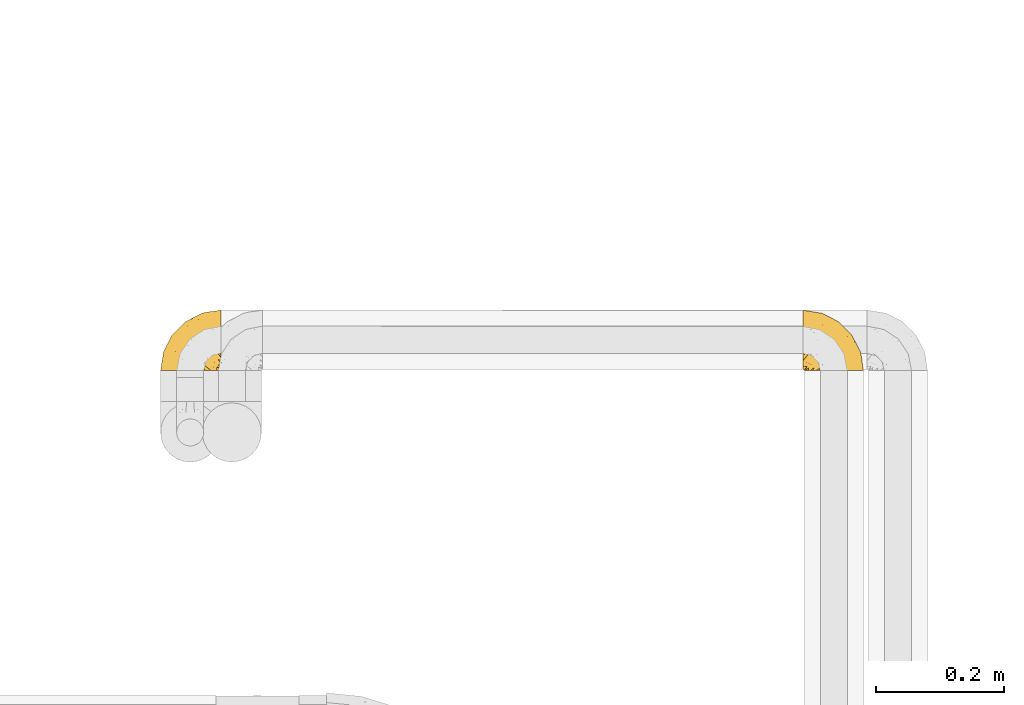
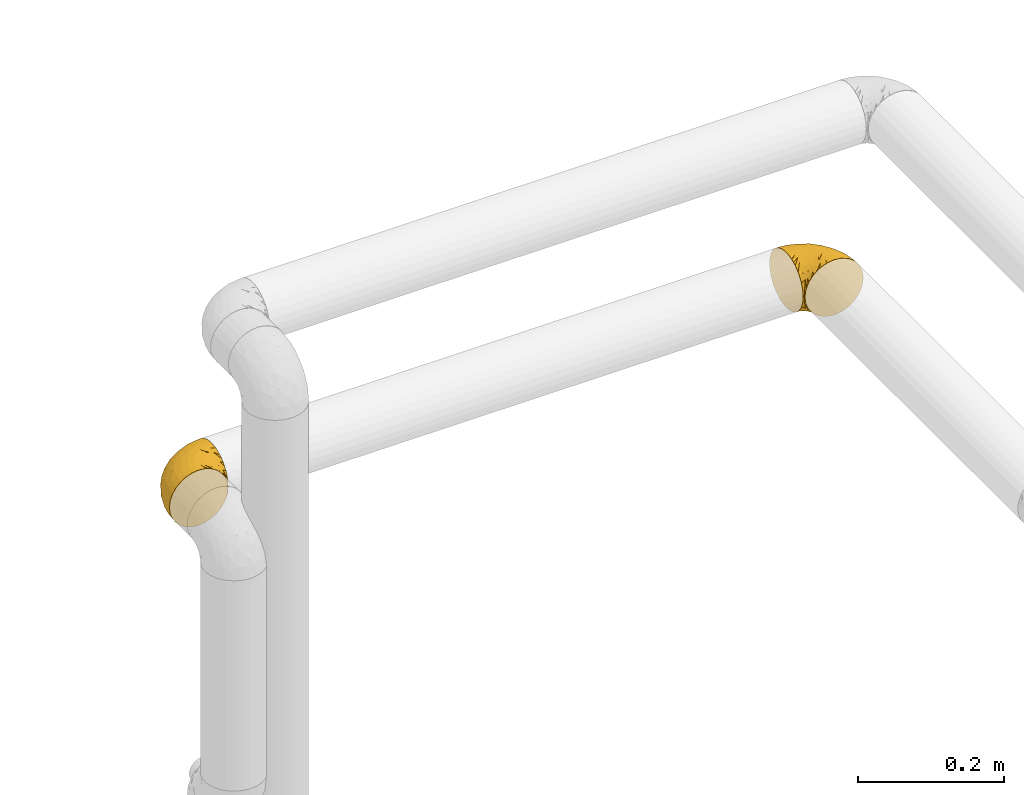
# One storey, part 513 of 827: 2 coverings.
"""IFC2X3 building model written with IfcOpenShell, lengths in millimetres."""

import ifcopenshell
import ifcopenshell.guid

model = None  # the IFC model being written
_history = None  # IfcOwnerHistory: only IFC2X3 demands one
_inside = {}  # id of a spatial element -> (the spatial element, [elements in it])
_under = {}  # id of a project, library or spatial element -> (it, [spatial elements below it])
_declared = {}  # id of a project -> (the project, [libraries it declares])
_typed = {}  # id of a type object -> (the type object, [elements of that type])
_made_of = {}  # id of a material, layer set ... -> (it, [elements and type objects made of it])


def new_model(schema):
    """Start an empty IFC model of exactly this schema.

    Asked for "IFC4X3", IfcOpenShell would pick the latest addendum, in which some entities
    have other attributes; the version numbers below select the first issue.
    IFC2X3 requires an IfcOwnerHistory on every rooted entity: one is made here for all.
    """
    global model, _history
    if schema == "IFC4X3":
        model = ifcopenshell.file(schema_version=(4, 3, 0, 0))
    else:
        model = ifcopenshell.file(schema=schema)
    _inside.clear()
    _under.clear()
    _declared.clear()
    _typed.clear()
    _made_of.clear()
    _history = None
    if model.schema == "IFC2X3":
        org = make("IfcOrganization", Name="unknown")
        user = make(
            "IfcPersonAndOrganization",
            ThePerson=make("IfcPerson", FamilyName="unknown"),
            TheOrganization=org,
        )
        app = make(
            "IfcApplication",
            ApplicationDeveloper=org,
            Version="unknown",
            ApplicationFullName="unknown",
            ApplicationIdentifier="unknown",
        )
        _history = make(
            "IfcOwnerHistory",
            OwningUser=user,
            OwningApplication=app,
            ChangeAction="ADDED",
            CreationDate=0,
        )
    return model


def make(cls, **values):
    """One entity of the class cls with the attributes given. An attribute that is None is left unset."""
    return model.create_entity(
        cls, **{name: value for name, value in values.items() if value is not None}
    )


def entity(cls, *values):
    """Any entity or typed value of the class cls, its attributes in the order of the schema. None: left unset."""
    e = model.create_entity(cls)
    for i, value in enumerate(values):
        if value is not None:
            e[i] = value
    return e


def rooted(cls, **values):
    """An entity with a GlobalId (a new one), such as an element, a storey or a relation."""
    return make(cls, GlobalId=ifcopenshell.guid.new(), OwnerHistory=_history, **values)


def si_unit(unit_type, name, prefix=None):
    """IfcSIUnit, for example si_unit("LENGTHUNIT", "METRE", prefix="MILLI")."""
    return make("IfcSIUnit", UnitType=unit_type, Prefix=prefix, Name=name)


def converted_unit(unit_type, name, factor, base, dimensions=None, offset=None):
    """IfcConversionBasedUnit, such as the inch: factor (a typed value) times the base unit."""
    return make(
        "IfcConversionBasedUnit"
        if offset is None
        else "IfcConversionBasedUnitWithOffset",
        ConversionOffset=offset,
        Dimensions=None
        if dimensions is None
        else entity("IfcDimensionalExponents", *dimensions),
        UnitType=unit_type,
        Name=name,
        ConversionFactor=make(
            "IfcMeasureWithUnit", ValueComponent=factor, UnitComponent=base
        ),
    )


def derived_unit(unit_type, elements):
    """IfcDerivedUnit: a product of units, each with its exponent."""
    return make(
        "IfcDerivedUnit",
        Elements=[
            make("IfcDerivedUnitElement", Unit=unit, Exponent=power)
            for unit, power in elements
        ],
        UnitType=unit_type,
    )


def assignment(units):
    """IfcUnitAssignment: the units of a project."""
    return None if units is None else make("IfcUnitAssignment", Units=units)


def point(xyz):
    """IfcCartesianPoint."""
    return None if xyz is None else make("IfcCartesianPoint", Coordinates=xyz)


def direction(xyz):
    """IfcDirection."""
    return None if xyz is None else make("IfcDirection", DirectionRatios=xyz)


def frame(location, z_axis=None, x_axis=None):
    """IfcAxis2Placement3D, a coordinate frame: its origin and axes. An axis left out is left unset."""
    return make(
        "IfcAxis2Placement3D",
        Location=point(location),
        Axis=direction(z_axis),
        RefDirection=direction(x_axis),
    )


def origin():
    """The frame at (0, 0, 0) with its axes left unset."""
    return frame((0.0, 0.0, 0.0))


def place(relative_to, where):
    """IfcLocalPlacement: puts the frame where relative to a parent placement (None: the world)."""
    return make(
        "IfcLocalPlacement", PlacementRelTo=relative_to, RelativePlacement=where
    )


def context(
    kind, dimensions, precision=None, world=None, true_north=None, identifier=None
):
    """IfcGeometricRepresentationContext, for example the 3D "Model" context."""
    return make(
        "IfcGeometricRepresentationContext",
        ContextIdentifier=identifier,
        ContextType=kind,
        CoordinateSpaceDimension=dimensions,
        Precision=precision,
        WorldCoordinateSystem=world,
        TrueNorth=true_north,
    )


def subcontext(parent, identifier, kind, view, scale=None):
    """IfcGeometricRepresentationSubContext, for example "Body" below "Model"."""
    return make(
        "IfcGeometricRepresentationSubContext",
        ContextIdentifier=identifier,
        ContextType=kind,
        ParentContext=parent,
        TargetScale=scale,
        TargetView=view,
    )


def project(units=None, contexts=None):
    """IfcProject with its units and contexts."""
    return rooted(
        "IfcProject",
        Name="project",
        RepresentationContexts=contexts,
        UnitsInContext=assignment(units),
    )


def spatial(cls, under=None, at=None, **own):
    """A site, building, storey or space (cls), placed at a placement, below another one or the project."""
    s = rooted(cls, ObjectPlacement=at, **own)
    if under is not None:
        _under.setdefault(under.id(), (under, []))[1].append(s)
    return s


def faces_of(points, faces, orient=None, outer=None):
    """IfcFace entities. A face is a list of loops; a loop is a list of indices into points, from 0.

    orient and outer hold one flag for each loop. By default every Orientation is true, the
    first loop of a face is its IfcFaceOuterBound and the others are IfcFaceBound.
    """
    made = []
    for i, loops in enumerate(faces):
        bounds = []
        for j, loop in enumerate(loops):
            is_outer = j == 0 if outer is None else outer[i][j]
            bounds.append(
                make(
                    "IfcFaceOuterBound" if is_outer else "IfcFaceBound",
                    Bound=make("IfcPolyLoop", Polygon=[points[k] for k in loop]),
                    Orientation=True if orient is None else orient[i][j],
                )
            )
        made.append(make("IfcFace", Bounds=bounds))
    return made


def faceted_brep(points, faces, orient=None, outer=None, voids=None):
    """IfcFacetedBrep: a solid bounded by flat faces; with voids (closed shells), ...WithVoids."""
    shared = [point(p) for p in points]
    hull = make("IfcClosedShell", CfsFaces=faces_of(shared, faces, orient, outer))
    if voids is None:
        return make("IfcFacetedBrep", Outer=hull)
    return make(
        "IfcFacetedBrepWithVoids",
        Outer=hull,
        Voids=[
            make(cls, CfsFaces=faces_of(shared, fs, o, b)) for cls, fs, o, b in voids
        ],
    )


def shape(context_of_items, identifier, shape_type, items):
    """IfcShapeRepresentation: the items that make up one representation, for example the "Body"."""
    return make(
        "IfcShapeRepresentation",
        ContextOfItems=context_of_items,
        RepresentationIdentifier=identifier,
        RepresentationType=shape_type,
        Items=items,
    )


def made_of(thing, what):
    """Note that an element or type object is made of a material, layer set ...; save() writes the relation."""
    if what is not None:
        _made_of.setdefault(what.id(), (what, []))[1].append(thing)
    return thing


def element(
    cls,
    number,
    at=None,
    inside=None,
    cuts=None,
    type_object=None,
    material=None,
    context=None,
    identifier="Body",
    shape_type=None,
    held_by="IfcProductDefinitionShape",
    body=None,
    shapes=None,
    **own,
):
    """One element of the class cls, such as IfcWall. Its Tag is "e" and its number.

    at: its placement. inside: the storey or other place that contains it. cuts: it is an
    opening in that element (IfcRelVoidsElement). A single representation is given by context,
    identifier, shape_type and body (its items); several are given by shapes. held_by: the class
    of the entity that holds the representations. save() writes the other relations.
    """
    e = rooted(cls, Tag="e%d" % number, ObjectPlacement=at, **own)
    if body is not None:
        shapes = [shape(context, identifier, shape_type, body)]
    if shapes is not None:
        e.Representation = make(held_by, Representations=shapes)
    if inside is not None:
        _inside.setdefault(inside.id(), (inside, []))[1].append(e)
    if cuts is not None:
        rooted(
            "IfcRelVoidsElement", RelatingBuildingElement=cuts, RelatedOpeningElement=e
        )
    if type_object is not None:
        _typed.setdefault(type_object.id(), (type_object, []))[1].append(e)
    return made_of(e, material)


def aggregate(whole, parts):
    """IfcRelAggregates: a whole, such as a stair, and the parts it consists of."""
    return rooted("IfcRelAggregates", RelatingObject=whole, RelatedObjects=parts)


def save(model, path):
    """Write the relations noted so far, then the file.

    IfcRelAggregates (storeys below a building ...), IfcRelContainedInSpatialStructure (elements
    in a storey), IfcRelDefinesByType, IfcRelAssociatesMaterial and IfcRelDeclares: one each for
    every whole, place, type object, material and project.
    """
    for whole, parts in _under.values():
        aggregate(whole, parts)
    for where, things in _inside.values():
        rooted(
            "IfcRelContainedInSpatialStructure",
            RelatedElements=things,
            RelatingStructure=where,
        )
    for kind, things in _typed.values():
        rooted("IfcRelDefinesByType", RelatedObjects=things, RelatingType=kind)
    for what, things in _made_of.values():
        rooted("IfcRelAssociatesMaterial", RelatedObjects=things, RelatingMaterial=what)
    for by, libraries in _declared.values():
        rooted("IfcRelDeclares", RelatingContext=by, RelatedDefinitions=libraries)
    model.write(path)


model = new_model("IFC2X3")

# Units and contexts
model_context = context("Model", 3, precision=0.01, world=origin(), true_north=direction((6.12303176911189e-17, 1.0)))
body_context = subcontext(model_context, "Body", "Model", "MODEL_VIEW")
ifc_project = project(units=[si_unit("LENGTHUNIT", "METRE", prefix="MILLI"), si_unit("AREAUNIT", "SQUARE_METRE"), si_unit("VOLUMEUNIT", "CUBIC_METRE"), converted_unit("PLANEANGLEUNIT", "DEGREE", entity("IfcRatioMeasure", 0.0174532925199433), si_unit("PLANEANGLEUNIT", "RADIAN"), dimensions=[0, 0, 0, 0, 0, 0, 0]), si_unit("MASSUNIT", "GRAM", prefix="KILO"), derived_unit("MASSDENSITYUNIT", [(si_unit("MASSUNIT", "GRAM", prefix="KILO"), 1), (si_unit("LENGTHUNIT", "METRE"), -3)]), derived_unit("MOMENTOFINERTIAUNIT", [(si_unit("LENGTHUNIT", "METRE"), 4)]), si_unit("TIMEUNIT", "SECOND"), si_unit("FREQUENCYUNIT", "HERTZ"), si_unit("THERMODYNAMICTEMPERATUREUNIT", "DEGREE_CELSIUS"), derived_unit("THERMALTRANSMITTANCEUNIT", [(si_unit("MASSUNIT", "GRAM", prefix="KILO"), 1), (si_unit("THERMODYNAMICTEMPERATUREUNIT", "KELVIN"), -1), (si_unit("TIMEUNIT", "SECOND"), -3)]), derived_unit("VOLUMETRICFLOWRATEUNIT", [(si_unit("LENGTHUNIT", "METRE"), 3), (si_unit("TIMEUNIT", "SECOND"), -1)]), derived_unit("MASSFLOWRATEUNIT", [(si_unit("MASSUNIT", "GRAM", prefix="KILO"), 1), (si_unit("TIMEUNIT", "SECOND"), -1)]), derived_unit("ROTATIONALFREQUENCYUNIT", [(si_unit("TIMEUNIT", "SECOND"), -1)]), si_unit("ELECTRICCURRENTUNIT", "AMPERE"), si_unit("ELECTRICVOLTAGEUNIT", "VOLT"), si_unit("POWERUNIT", "WATT"), si_unit("FORCEUNIT", "NEWTON", prefix="KILO"), si_unit("ILLUMINANCEUNIT", "LUX"), si_unit("LUMINOUSFLUXUNIT", "LUMEN"), si_unit("LUMINOUSINTENSITYUNIT", "CANDELA"), derived_unit("USERDEFINED", [(si_unit("MASSUNIT", "GRAM", prefix="KILO"), -1), (si_unit("LENGTHUNIT", "METRE"), -2), (si_unit("TIMEUNIT", "SECOND"), 3), (si_unit("LUMINOUSFLUXUNIT", "LUMEN"), 1)]), derived_unit("LINEARVELOCITYUNIT", [(si_unit("LENGTHUNIT", "METRE"), 1), (si_unit("TIMEUNIT", "SECOND"), -1)]), si_unit("PRESSUREUNIT", "PASCAL"), derived_unit("USERDEFINED", [(si_unit("LENGTHUNIT", "METRE"), -2), (si_unit("MASSUNIT", "GRAM", prefix="KILO"), 1), (si_unit("TIMEUNIT", "SECOND"), -2)]), derived_unit("LINEARFORCEUNIT", [(si_unit("MASSUNIT", "GRAM", prefix="KILO"), 1), (si_unit("LENGTHUNIT", "METRE"), 1), (si_unit("TIMEUNIT", "SECOND"), -2), (si_unit("LENGTHUNIT", "METRE"), -1)]), derived_unit("PLANARFORCEUNIT", [(si_unit("MASSUNIT", "GRAM", prefix="KILO"), 1), (si_unit("LENGTHUNIT", "METRE"), 1), (si_unit("TIMEUNIT", "SECOND"), -2), (si_unit("LENGTHUNIT", "METRE"), -2)])], contexts=[model_context])

# Site, building, storey
site_placement = place(None, origin())
site = spatial("IfcSite", under=ifc_project, at=site_placement, CompositionType="ELEMENT")
building_placement = place(site_placement, origin())
building = spatial("IfcBuilding", under=site, at=building_placement, CompositionType="ELEMENT")
storey_placement = place(building_placement, frame((0.0, 0.0, 28200.0)))
storey = spatial("IfcBuildingStorey", under=building, at=storey_placement, Name="08", CompositionType="ELEMENT", Elevation=28200.0)

# Coverings
covering_1_placement = place(storey_placement, frame((61003.04, 18766.35, 2041.58)))
element("IfcCovering", 1, at=covering_1_placement, inside=storey, Name=":ADSK_", ObjectType=":ADSK_", PredefinedType="INSULATION", context=body_context, shape_type="Brep", body=[
    faceted_brep([(1.6, 78.41, 83.91), (1.6, 85.72, 76.59), (1.6, 91.22, 67.83), (1.6, 94.64, 58.07), (1.6, 95.8, 47.8), (1.6, 94.64, 37.51), (1.6, 91.22, 27.74), (1.6, 85.71, 18.98), (1.6, 78.39, 11.67), (1.6, 69.63, 6.17), (1.6, 59.87, 2.75), (1.6, 49.6, 1.6), (1.6, 45.45, 2.06), (1.6, 42.38, 2.41), (1.6, 39.31, 2.75), (1.6, 34.43, 4.46), (1.6, 29.54, 6.17), (1.6, 25.16, 8.93), (1.6, 20.78, 11.68), (1.6, 17.13, 15.34), (1.6, 13.47, 19.0), (1.6, 7.97, 27.76), (1.6, 6.26, 32.64), (1.6, 4.55, 37.52), (1.6, 3.4, 47.8), (1.6, 4.55, 58.08), (1.6, 6.26, 62.96), (1.6, 7.97, 67.85), (1.6, 13.48, 76.61), (1.6, 17.14, 80.26), (1.6, 20.8, 83.92), (1.6, 25.18, 86.67), (1.6, 29.56, 89.42), (1.6, 34.44, 91.13), (1.6, 39.32, 92.84), (1.6, 42.39, 93.18), (1.6, 45.45, 93.53), (1.6, 49.6, 94.0), (1.6, 59.88, 92.84), (1.6, 69.65, 89.42), (3.4, 1.6, 47.8), (4.97, 1.6, 35.84), (9.58, 1.6, 24.7), (13.26, 1.6, 19.91), (16.93, 1.6, 15.13), (21.71, 1.6, 11.46), (26.5, 1.6, 7.78), (32.07, 1.6, 5.48), (37.64, 1.6, 3.17), (41.25, 1.6, 2.69), (43.34, 1.6, 2.42), (45.42, 1.6, 2.14), (49.6, 1.6, 1.6), (61.55, 1.6, 3.17), (72.7, 1.6, 7.78), (82.26, 1.6, 15.13), (89.61, 1.6, 24.7), (94.22, 1.6, 35.84), (95.8, 1.6, 47.8), (94.22, 1.6, 59.75), (89.61, 1.6, 70.9), (82.26, 1.6, 80.46), (72.7, 1.6, 87.81), (61.55, 1.6, 92.42), (49.6, 1.6, 94.0), (45.42, 1.6, 93.45), (41.25, 1.6, 92.9), (37.64, 1.6, 92.42), (32.07, 1.6, 90.11), (26.5, 1.6, 87.81), (21.71, 1.6, 84.13), (16.93, 1.6, 80.46), (13.26, 1.6, 75.68), (9.58, 1.6, 70.9), (4.97, 1.6, 59.75), (81.55, 36.81, 71.98), (90.4, 23.28, 63.6), (83.0, 45.8, 59.72), (91.18, 30.7, 47.8), (93.13, 21.2, 55.16), (94.0, 12.96, 47.8), (66.19, 66.19, 63.76), (70.92, 54.51, 72.22), (85.95, 17.98, 74.18), (49.74, 36.69, 92.52), (35.54, 35.54, 94.0), (38.14, 31.64, 94.0), (40.74, 27.75, 94.0), (43.34, 23.86, 94.0), (45.94, 19.96, 94.0), (77.59, 22.8, 82.14), (71.17, 42.67, 80.34), (65.81, 33.21, 87.52), (59.03, 59.45, 79.59), (45.85, 71.5, 78.25), (45.79, 62.66, 85.01), (41.42, 54.5, 90.25), (34.51, 47.57, 93.2), (56.04, 48.81, 87.23), (15.15, 74.98, 85.55), (56.51, 18.7, 93.0), (68.39, 15.75, 89.31), (23.33, 91.17, 61.31), (42.86, 85.28, 56.86), (39.42, 82.58, 68.34), (53.58, 75.78, 65.71), (59.17, 74.98, 56.99), (59.06, 67.27, 72.15), (22.63, 87.38, 70.34), (20.55, 82.04, 78.36), (12.96, 94.0, 47.8), (56.96, 77.8, 47.8), (67.38, 67.38, 47.8), (18.72, 56.2, 93.06), (5.33, 48.85, 94.0), (9.07, 48.11, 94.0), (11.79, 47.57, 94.0), (14.51, 47.03, 94.0), (17.24, 46.48, 94.0), (19.96, 45.94, 94.0), (21.03, 65.78, 89.88), (46.48, 17.24, 94.0), (47.03, 14.51, 94.0), (47.57, 11.79, 94.0), (48.11, 9.07, 94.0), (48.48, 7.2, 94.0), (48.85, 5.33, 94.0), (30.7, 91.18, 47.8), (23.86, 43.34, 94.0), (27.75, 40.74, 94.0), (31.64, 38.14, 94.0), (31.26, 72.73, 83.7), (77.8, 56.96, 47.8), (72.75, 62.23, 55.9), (43.83, 84.49, 47.8), (84.49, 43.83, 47.8), (14.58, 12.05, 81.75), (16.17, 18.95, 86.43), (10.82, 13.02, 79.8), (4.64, 8.34, 69.84), (7.71, 14.63, 79.5), (25.13, 11.09, 88.08), (32.66, 13.66, 91.6), (34.94, 20.08, 92.93), (36.76, 9.61, 92.43), (40.48, 9.48, 93.24), (39.25, 16.1, 93.36), (3.69, 3.42, 57.25), (13.99, 26.63, 89.41), (21.85, 33.72, 92.89), (17.93, 34.77, 92.66), (15.11, 6.75, 79.58), (21.14, 13.31, 86.51), (12.7, 21.11, 86.29), (7.21, 19.94, 83.91), (10.45, 6.04, 73.94), (32.27, 8.67, 90.94), (25.68, 26.11, 91.94), (22.18, 29.3, 91.98), (18.79, 6.32, 82.79), (10.12, 39.92, 93.16), (9.47, 27.05, 88.76), (11.29, 34.4, 91.89), (2.87, 2.87, 47.8), (31.16, 20.92, 92.22), (6.31, 27.43, 88.56), (25.62, 7.54, 87.72), (21.18, 18.45, 88.33), (28.81, 23.88, 92.18), (7.45, 7.77, 71.78), (21.17, 18.43, 7.27), (16.17, 18.93, 9.17), (25.69, 26.08, 3.66), (48.11, 9.07, 1.6), (48.85, 5.33, 1.6), (47.03, 14.51, 1.6), (47.57, 11.79, 1.6), (3.69, 3.42, 38.35), (7.44, 7.76, 23.84), (14.51, 47.03, 1.6), (11.79, 47.57, 1.6), (5.33, 48.85, 1.6), (9.07, 48.11, 1.6), (7.71, 14.62, 16.1), (9.47, 27.03, 6.84), (34.94, 20.08, 2.66), (31.16, 20.92, 3.37), (40.74, 27.75, 1.6), (38.14, 31.64, 1.6), (18.79, 6.33, 12.8), (36.76, 9.61, 3.16), (40.48, 9.48, 2.35), (4.63, 8.33, 25.77), (21.14, 13.3, 9.09), (15.11, 6.74, 16.02), (14.58, 12.04, 13.85), (43.34, 23.86, 1.6), (45.94, 19.96, 1.6), (39.25, 16.1, 2.23), (7.21, 19.93, 11.69), (12.69, 21.1, 9.31), (10.14, 39.92, 2.43), (21.81, 33.68, 2.71), (22.19, 29.28, 3.61), (14.0, 26.62, 6.18), (6.66, 27.87, 6.77), (17.92, 34.75, 2.93), (10.45, 6.04, 21.66), (31.64, 38.14, 1.6), (10.64, 12.79, 16.09), (11.31, 34.41, 3.7), (19.96, 45.94, 1.6), (23.86, 43.34, 1.6), (27.75, 40.74, 1.6), (32.66, 13.66, 3.99), (46.48, 17.24, 1.6), (32.27, 8.67, 4.65), (25.13, 11.09, 7.51), (35.54, 35.54, 1.6), (28.77, 23.83, 3.43), (23.36, 6.03, 9.46), (17.24, 46.48, 1.6), (47.58, 34.52, 2.4), (93.13, 21.2, 40.43), (77.44, 23.82, 13.57), (66.78, 41.32, 11.3), (71.68, 47.62, 18.65), (74.96, 52.66, 27.26), (81.55, 36.81, 23.61), (36.7, 49.75, 3.07), (56.9, 19.07, 2.69), (83.0, 45.8, 35.87), (90.4, 23.28, 31.99), (67.83, 21.35, 6.71), (85.95, 17.98, 21.41), (39.41, 82.57, 27.24), (23.33, 91.17, 34.26), (42.87, 85.27, 38.73), (53.92, 73.89, 26.97), (66.19, 66.19, 31.83), (64.12, 62.43, 23.4), (33.13, 63.53, 6.91), (23.1, 58.45, 3.4), (16.98, 67.16, 5.84), (72.75, 62.22, 39.69), (23.77, 81.54, 17.6), (18.41, 74.8, 10.38), (43.7, 75.83, 20.6), (54.53, 41.45, 5.36), (55.72, 76.72, 35.73), (17.73, 88.2, 24.84), (38.98, 71.6, 13.87), (50.28, 56.23, 9.06), (59.02, 59.44, 15.99)], [[[0, 1, 2, 3, 4, 5, 6, 7, 8, 9, 10, 11, 12, 13, 14, 15, 16, 17, 18, 19, 20, 21, 22, 23, 24, 25, 26, 27, 28, 29, 30, 31, 32, 33, 34, 35, 36, 37, 38, 39]], [[40, 41, 42, 43, 44, 45, 46, 47, 48, 49, 50, 51, 52, 53, 54, 55, 56, 57, 58, 59, 60, 61, 62, 63, 64, 65, 66, 67, 68, 69, 70, 71, 72, 73, 74]], [[75, 76, 77]], [[78, 79, 80]], [[77, 81, 82]], [[76, 75, 83]], [[84, 85, 86, 87, 88, 89]], [[90, 91, 92]], [[76, 60, 59]], [[93, 94, 95]], [[90, 62, 61]], [[83, 61, 60]], [[96, 97, 84]], [[98, 93, 95]], [[0, 39, 99]], [[100, 84, 89]], [[62, 101, 63]], [[2, 102, 3]], [[92, 84, 100]], [[103, 102, 104]], [[103, 105, 106]], [[93, 107, 94]], [[1, 108, 2]], [[92, 101, 90]], [[108, 1, 109]], [[102, 110, 3]], [[93, 82, 107]], [[102, 108, 104]], [[111, 106, 112]], [[109, 0, 99]], [[113, 37, 114, 115, 116, 117, 118, 119]], [[120, 38, 113]], [[100, 89, 121, 122, 123, 124, 125, 126, 64]], [[127, 102, 103]], [[97, 119, 128, 129, 130, 85]], [[99, 120, 131]], [[132, 133, 77]], [[59, 80, 79]], [[1, 0, 109]], [[98, 84, 92]], [[94, 109, 131]], [[120, 39, 38]], [[93, 91, 82]], [[104, 94, 105]], [[97, 113, 119]], [[95, 120, 96]], [[83, 90, 61]], [[91, 93, 98]], [[64, 63, 100]], [[100, 63, 101]], [[77, 76, 79]], [[133, 106, 81]], [[84, 97, 85]], [[113, 96, 120]], [[113, 97, 96]], [[37, 113, 38]], [[110, 102, 127]], [[110, 4, 3]], [[103, 111, 134, 127]], [[90, 75, 91]], [[82, 81, 107]], [[91, 75, 82]], [[77, 82, 75]], [[76, 83, 60]], [[90, 83, 75]], [[105, 107, 81]], [[94, 131, 95]], [[105, 94, 107]], [[109, 94, 104]], [[120, 95, 131]], [[98, 95, 96]], [[84, 98, 96]], [[98, 92, 91]], [[106, 105, 81]], [[103, 104, 105]], [[112, 106, 133]], [[103, 106, 111]], [[112, 133, 132]], [[81, 77, 133]], [[77, 78, 135, 132]], [[120, 99, 39]], [[109, 99, 131]], [[59, 58, 80]], [[59, 79, 76]], [[90, 101, 62]], [[100, 101, 92]], [[2, 108, 102]], [[109, 104, 108]], [[78, 77, 79]], [[136, 137, 138]], [[27, 139, 140]], [[141, 142, 143]], [[144, 145, 121]], [[146, 89, 88]], [[147, 139, 25]], [[148, 149, 150]], [[136, 151, 152]], [[147, 40, 74]], [[24, 147, 25]], [[140, 153, 154]], [[33, 116, 34]], [[73, 151, 155]], [[114, 37, 36, 35, 34, 116, 115]], [[146, 156, 144]], [[157, 85, 130]], [[158, 149, 148]], [[151, 159, 152]], [[117, 33, 160]], [[29, 154, 161]], [[155, 74, 73]], [[162, 128, 119]], [[65, 64, 126, 125, 124, 123, 122, 67, 66]], [[163, 147, 24]], [[27, 140, 28]], [[149, 129, 150]], [[139, 27, 26, 25]], [[68, 144, 69]], [[129, 128, 150]], [[164, 87, 86]], [[130, 129, 149]], [[122, 145, 67]], [[154, 153, 148]], [[162, 119, 160]], [[165, 30, 161]], [[150, 161, 148]], [[128, 162, 150]], [[30, 165, 31]], [[145, 144, 68]], [[89, 146, 144]], [[87, 164, 143]], [[166, 156, 142]], [[88, 87, 143]], [[162, 161, 150]], [[161, 30, 29]], [[154, 29, 28]], [[140, 154, 28]], [[161, 154, 148]], [[140, 137, 153]], [[158, 148, 153]], [[157, 130, 158]], [[153, 137, 158]], [[158, 137, 157]], [[167, 137, 136]], [[168, 85, 157]], [[152, 168, 167]], [[167, 168, 157]], [[164, 152, 141]], [[151, 73, 72]], [[159, 72, 71]], [[88, 142, 146]], [[144, 156, 69]], [[146, 142, 156]], [[70, 166, 71]], [[142, 141, 166]], [[70, 69, 156]], [[141, 159, 71]], [[167, 136, 152]], [[138, 137, 140]], [[155, 136, 169]], [[136, 155, 151]], [[74, 155, 169]], [[152, 159, 141]], [[151, 72, 159]], [[168, 152, 164]], [[137, 167, 157]], [[164, 86, 168]], [[85, 168, 86]], [[116, 33, 117]], [[130, 149, 158]], [[67, 145, 68]], [[121, 89, 144]], [[145, 122, 121]], [[40, 147, 163]], [[169, 147, 74]], [[160, 33, 32]], [[162, 160, 32]], [[160, 119, 118, 117]], [[139, 147, 169]], [[139, 169, 138]], [[162, 32, 31]], [[141, 143, 164]], [[88, 143, 142]], [[71, 166, 141]], [[156, 166, 70]], [[139, 138, 140]], [[169, 136, 138]], [[161, 162, 165]], [[162, 31, 165]], [[170, 171, 172]], [[173, 174, 52, 51, 50, 49, 48, 175, 176]], [[177, 178, 41]], [[179, 15, 180]], [[12, 11, 181, 182, 180, 14, 13]], [[183, 21, 20]], [[19, 18, 184]], [[185, 186, 187]], [[186, 188, 187]], [[43, 189, 44]], [[190, 191, 47]], [[23, 22, 21, 192]], [[193, 194, 195]], [[40, 163, 177]], [[196, 197, 198]], [[24, 23, 177]], [[199, 200, 183]], [[201, 15, 179]], [[178, 177, 192]], [[47, 46, 190]], [[202, 203, 204]], [[203, 172, 171]], [[205, 206, 184]], [[207, 41, 178]], [[16, 15, 201]], [[14, 180, 15]], [[204, 203, 200]], [[208, 203, 202]], [[163, 24, 177]], [[48, 47, 191]], [[198, 197, 190]], [[199, 184, 204]], [[171, 195, 209]], [[210, 211, 212]], [[206, 212, 213]], [[205, 17, 210]], [[184, 206, 204]], [[210, 212, 206]], [[185, 196, 214]], [[190, 215, 191]], [[216, 45, 214]], [[186, 217, 193]], [[190, 216, 198]], [[199, 20, 19]], [[196, 185, 187]], [[199, 183, 20]], [[184, 199, 19]], [[199, 204, 200]], [[206, 202, 204]], [[171, 183, 200]], [[203, 208, 172]], [[172, 208, 218]], [[171, 200, 203]], [[218, 188, 219]], [[195, 170, 193]], [[217, 186, 185]], [[193, 219, 186]], [[193, 170, 219]], [[207, 194, 42]], [[217, 220, 189]], [[216, 190, 46]], [[214, 196, 198]], [[44, 220, 45]], [[214, 198, 216]], [[216, 46, 45]], [[214, 45, 220]], [[42, 194, 43]], [[189, 193, 217]], [[207, 195, 194]], [[209, 195, 178]], [[41, 207, 42]], [[195, 207, 178]], [[43, 194, 189]], [[193, 189, 194]], [[171, 170, 195]], [[170, 172, 219]], [[218, 219, 172]], [[188, 186, 219]], [[206, 213, 202]], [[208, 202, 213]], [[201, 210, 16]], [[215, 190, 197]], [[215, 175, 191]], [[175, 48, 191]], [[201, 179, 221, 211]], [[210, 201, 211]], [[23, 192, 177]], [[40, 177, 41]], [[192, 183, 209]], [[21, 183, 192]], [[205, 18, 17]], [[17, 16, 210]], [[217, 185, 214]], [[189, 220, 44]], [[214, 220, 217]], [[192, 209, 178]], [[171, 209, 183]], [[206, 205, 210]], [[18, 205, 184]], [[222, 197, 196, 187, 188, 218]], [[57, 223, 80]], [[224, 225, 226]], [[226, 227, 228]], [[229, 218, 208, 213, 212, 211]], [[230, 52, 174, 173, 176, 175, 215, 197]], [[231, 232, 228]], [[231, 78, 223]], [[223, 57, 232]], [[224, 233, 225]], [[233, 54, 53]], [[234, 232, 56]], [[56, 55, 234]], [[234, 224, 228]], [[235, 236, 237]], [[224, 55, 54]], [[238, 239, 240]], [[52, 230, 53]], [[241, 242, 243]], [[231, 227, 244]], [[11, 10, 242]], [[236, 6, 5]], [[7, 245, 8]], [[8, 246, 9]], [[238, 247, 235]], [[222, 229, 248]], [[242, 211, 221, 179, 180, 182, 181, 11]], [[233, 53, 230]], [[111, 112, 249]], [[250, 6, 236]], [[246, 251, 241]], [[6, 250, 7]], [[127, 236, 110]], [[248, 229, 252]], [[246, 8, 245]], [[235, 245, 250]], [[236, 5, 110]], [[235, 249, 238]], [[237, 236, 127]], [[243, 9, 246]], [[252, 229, 241]], [[56, 232, 57]], [[222, 230, 197]], [[225, 248, 252]], [[248, 233, 230]], [[54, 233, 224]], [[231, 228, 227]], [[244, 132, 231]], [[248, 225, 233]], [[226, 225, 253]], [[235, 250, 236]], [[245, 7, 250]], [[251, 246, 245]], [[243, 246, 241]], [[247, 245, 235]], [[252, 251, 253]], [[229, 222, 218]], [[230, 222, 248]], [[5, 4, 110]], [[237, 127, 134, 111]], [[238, 249, 239]], [[224, 234, 55]], [[232, 234, 228]], [[242, 241, 229]], [[10, 9, 243]], [[211, 242, 229]], [[10, 243, 242]], [[80, 223, 78]], [[80, 58, 57]], [[231, 223, 232]], [[227, 240, 239]], [[224, 226, 228]], [[240, 226, 253]], [[227, 239, 244]], [[226, 240, 227]], [[251, 247, 253]], [[240, 253, 247]], [[249, 235, 237]], [[237, 111, 249]], [[244, 239, 249]], [[112, 244, 249]], [[135, 78, 231, 132]], [[112, 132, 244]], [[247, 238, 240]], [[245, 247, 251]], [[251, 252, 241]], [[225, 252, 253]]]),
])
covering_2_placement = place(storey_placement, frame((60000.38, 18766.5, 2041.58)))
element("IfcCovering", 2, at=covering_2_placement, inside=storey, Name=":ADSK_", ObjectType=":ADSK_", PredefinedType="INSULATION", context=body_context, shape_type="Brep", body=[
    faceted_brep([(18.98, 1.6, 83.91), (11.67, 1.6, 76.59), (6.17, 1.6, 67.83), (2.75, 1.6, 58.07), (1.6, 1.6, 47.8), (2.75, 1.6, 37.51), (6.17, 1.6, 27.74), (11.68, 1.6, 18.98), (19.0, 1.6, 11.67), (27.76, 1.6, 6.17), (37.52, 1.6, 2.75), (47.8, 1.6, 1.6), (51.94, 1.6, 2.06), (55.01, 1.6, 2.41), (58.08, 1.6, 2.75), (62.96, 1.6, 4.46), (67.85, 1.6, 6.17), (72.23, 1.6, 8.93), (76.61, 1.6, 11.68), (80.26, 1.6, 15.34), (83.92, 1.6, 19.0), (89.42, 1.6, 27.76), (91.13, 1.6, 32.64), (92.84, 1.6, 37.52), (94.0, 1.6, 47.8), (92.84, 1.6, 58.08), (91.13, 1.6, 62.96), (89.42, 1.6, 67.85), (83.91, 1.6, 76.61), (80.25, 1.6, 80.26), (76.59, 1.6, 83.92), (72.21, 1.6, 86.67), (67.83, 1.6, 89.42), (62.95, 1.6, 91.13), (58.07, 1.6, 92.84), (55.0, 1.6, 93.18), (51.94, 1.6, 93.53), (47.8, 1.6, 94.0), (37.51, 1.6, 92.84), (27.74, 1.6, 89.42), (95.8, 3.4, 47.8), (95.8, 4.97, 35.84), (95.8, 9.58, 24.7), (95.8, 13.26, 19.91), (95.8, 16.93, 15.13), (95.8, 21.71, 11.46), (95.8, 26.5, 7.78), (95.8, 32.07, 5.48), (95.8, 37.64, 3.17), (95.8, 41.25, 2.69), (95.8, 43.34, 2.42), (95.8, 45.42, 2.14), (95.8, 49.6, 1.6), (95.8, 61.55, 3.17), (95.8, 72.7, 7.78), (95.8, 82.26, 15.13), (95.8, 89.61, 24.7), (95.8, 94.22, 35.84), (95.8, 95.8, 47.8), (95.8, 94.22, 59.75), (95.8, 89.61, 70.9), (95.8, 82.26, 80.46), (95.8, 72.7, 87.81), (95.8, 61.55, 92.42), (95.8, 49.6, 94.0), (95.8, 45.42, 93.45), (95.8, 41.25, 92.9), (95.8, 37.64, 92.42), (95.8, 32.07, 90.11), (95.8, 26.5, 87.81), (95.8, 21.71, 84.13), (95.8, 16.93, 80.46), (95.8, 13.26, 75.68), (95.8, 9.58, 70.9), (95.8, 4.97, 59.75), (60.58, 81.55, 71.98), (74.11, 90.4, 63.6), (51.59, 83.0, 59.72), (66.69, 91.18, 47.8), (76.19, 93.13, 55.16), (84.43, 94.0, 47.8), (31.2, 66.19, 63.76), (42.88, 70.92, 72.22), (79.41, 85.95, 74.18), (60.7, 49.74, 92.52), (61.85, 35.54, 94.0), (65.75, 38.14, 94.0), (69.64, 40.74, 94.0), (73.53, 43.34, 94.0), (77.43, 45.94, 94.0), (74.59, 77.59, 82.14), (54.72, 71.17, 80.34), (64.18, 65.81, 87.52), (37.94, 59.03, 79.59), (25.89, 45.85, 78.25), (34.73, 45.79, 85.01), (42.89, 41.42, 90.25), (49.83, 34.51, 93.2), (48.58, 56.04, 87.23), (22.41, 15.15, 85.55), (78.69, 56.51, 93.0), (81.64, 68.39, 89.31), (6.22, 23.33, 61.31), (12.11, 42.86, 56.86), (14.81, 39.42, 68.34), (21.61, 53.58, 65.71), (22.41, 59.17, 56.99), (30.12, 59.06, 72.15), (10.01, 22.63, 70.34), (15.36, 20.55, 78.36), (3.39, 12.96, 47.8), (19.59, 56.96, 47.8), (30.01, 67.38, 47.8), (41.19, 18.72, 93.06), (48.54, 5.33, 94.0), (49.28, 9.07, 94.0), (49.82, 11.79, 94.0), (50.37, 14.51, 94.0), (50.91, 17.24, 94.0), (51.45, 19.96, 94.0), (31.61, 21.03, 89.88), (80.15, 46.48, 94.0), (82.88, 47.03, 94.0), (85.6, 47.57, 94.0), (88.32, 48.11, 94.0), (90.19, 48.48, 94.0), (92.06, 48.85, 94.0), (6.21, 30.7, 47.8), (54.05, 23.86, 94.0), (56.65, 27.75, 94.0), (59.25, 31.64, 94.0), (24.66, 31.26, 83.7), (40.43, 77.8, 47.8), (35.17, 72.75, 55.9), (12.9, 43.83, 47.8), (53.56, 84.49, 47.8), (85.34, 14.58, 81.75), (78.44, 16.17, 86.43), (84.37, 10.82, 79.8), (89.05, 4.64, 69.84), (82.76, 7.71, 79.5), (86.31, 25.13, 88.08), (83.73, 32.66, 91.6), (77.31, 34.94, 92.93), (87.78, 36.76, 92.43), (87.91, 40.48, 93.24), (81.29, 39.25, 93.36), (93.97, 3.69, 57.25), (70.76, 13.99, 89.41), (63.67, 21.85, 92.89), (62.62, 17.93, 92.66), (90.64, 15.11, 79.58), (84.08, 21.14, 86.51), (76.28, 12.7, 86.29), (77.45, 7.21, 83.91), (91.35, 10.45, 73.94), (88.72, 32.27, 90.94), (71.28, 25.68, 91.94), (68.09, 22.18, 91.98), (91.07, 18.79, 82.79), (57.47, 10.12, 93.16), (70.34, 9.47, 88.76), (62.99, 11.29, 91.89), (94.52, 2.87, 47.8), (76.47, 31.16, 92.22), (69.96, 6.31, 88.56), (89.86, 25.62, 87.72), (78.94, 21.18, 88.33), (73.51, 28.81, 92.18), (89.62, 7.45, 71.78), (84.09, 21.14, 9.09), (86.3, 25.13, 7.51), (91.06, 18.79, 12.8), (88.32, 48.11, 1.6), (92.06, 48.85, 1.6), (82.88, 47.03, 1.6), (85.6, 47.57, 1.6), (93.97, 3.69, 38.35), (89.63, 7.44, 23.84), (50.37, 14.51, 1.6), (49.82, 11.79, 1.6), (48.54, 5.33, 1.6), (49.28, 9.07, 1.6), (82.77, 7.71, 16.1), (70.36, 9.47, 6.84), (77.31, 34.94, 2.66), (76.47, 31.16, 3.37), (69.64, 40.74, 1.6), (65.75, 38.14, 1.6), (87.78, 36.76, 3.16), (87.91, 40.48, 2.35), (89.06, 4.63, 25.77), (90.65, 15.11, 16.02), (85.35, 14.58, 13.85), (73.53, 43.34, 1.6), (77.43, 45.94, 1.6), (81.29, 39.25, 2.23), (77.46, 7.21, 11.69), (76.29, 12.69, 9.31), (57.47, 10.14, 2.43), (63.71, 21.81, 2.71), (68.11, 22.19, 3.61), (70.77, 14.0, 6.18), (71.31, 25.69, 3.66), (78.46, 16.17, 9.17), (69.52, 6.66, 6.77), (62.64, 17.92, 2.93), (91.35, 10.45, 21.66), (59.25, 31.64, 1.6), (84.6, 10.64, 16.09), (62.98, 11.31, 3.7), (51.45, 19.96, 1.6), (54.05, 23.86, 1.6), (56.65, 27.75, 1.6), (83.73, 32.66, 3.99), (80.15, 46.48, 1.6), (88.72, 32.27, 4.65), (61.85, 35.54, 1.6), (73.56, 28.77, 3.43), (78.96, 21.17, 7.27), (91.36, 23.36, 9.46), (50.91, 17.24, 1.6), (62.87, 47.58, 2.4), (76.19, 93.13, 40.43), (73.57, 77.44, 13.57), (56.07, 66.78, 11.3), (49.77, 71.68, 18.65), (44.73, 74.96, 27.26), (60.58, 81.55, 23.61), (47.64, 36.7, 3.07), (78.32, 56.9, 2.69), (51.59, 83.0, 35.87), (74.11, 90.4, 31.99), (76.04, 67.83, 6.71), (79.41, 85.95, 21.41), (14.82, 39.41, 27.24), (6.22, 23.33, 34.26), (12.12, 42.87, 38.73), (23.51, 53.92, 26.97), (31.2, 66.19, 31.83), (34.96, 64.12, 23.4), (33.86, 33.13, 6.91), (38.94, 23.1, 3.4), (30.23, 16.98, 5.84), (35.17, 72.75, 39.69), (15.85, 23.77, 17.6), (22.59, 18.41, 10.38), (21.56, 43.7, 20.6), (55.94, 54.53, 5.36), (20.67, 55.72, 35.73), (9.19, 17.73, 24.84), (25.79, 38.98, 13.87), (41.16, 50.28, 9.06), (37.95, 59.02, 15.99)], [[[0, 1, 2, 3, 4, 5, 6, 7, 8, 9, 10, 11, 12, 13, 14, 15, 16, 17, 18, 19, 20, 21, 22, 23, 24, 25, 26, 27, 28, 29, 30, 31, 32, 33, 34, 35, 36, 37, 38, 39]], [[40, 41, 42, 43, 44, 45, 46, 47, 48, 49, 50, 51, 52, 53, 54, 55, 56, 57, 58, 59, 60, 61, 62, 63, 64, 65, 66, 67, 68, 69, 70, 71, 72, 73, 74]], [[75, 76, 77]], [[78, 79, 80]], [[77, 81, 82]], [[76, 75, 83]], [[84, 85, 86, 87, 88, 89]], [[90, 91, 92]], [[76, 60, 59]], [[93, 94, 95]], [[90, 62, 61]], [[83, 61, 60]], [[96, 97, 84]], [[98, 93, 95]], [[0, 39, 99]], [[100, 84, 89]], [[62, 101, 63]], [[2, 102, 3]], [[92, 84, 100]], [[103, 102, 104]], [[103, 105, 106]], [[93, 107, 94]], [[1, 108, 2]], [[92, 101, 90]], [[108, 1, 109]], [[102, 110, 3]], [[93, 82, 107]], [[102, 108, 104]], [[111, 106, 112]], [[109, 0, 99]], [[113, 37, 114, 115, 116, 117, 118, 119]], [[120, 38, 113]], [[100, 89, 121, 122, 123, 124, 125, 126, 64]], [[127, 102, 103]], [[97, 119, 128, 129, 130, 85]], [[99, 120, 131]], [[132, 133, 77]], [[59, 80, 79]], [[1, 0, 109]], [[98, 84, 92]], [[94, 109, 131]], [[120, 39, 38]], [[93, 91, 82]], [[104, 94, 105]], [[97, 113, 119]], [[95, 120, 96]], [[83, 90, 61]], [[91, 93, 98]], [[64, 63, 100]], [[100, 63, 101]], [[77, 76, 79]], [[133, 106, 81]], [[84, 97, 85]], [[113, 96, 120]], [[113, 97, 96]], [[37, 113, 38]], [[110, 102, 127]], [[110, 4, 3]], [[103, 111, 134, 127]], [[90, 75, 91]], [[82, 81, 107]], [[91, 75, 82]], [[77, 82, 75]], [[76, 83, 60]], [[90, 83, 75]], [[105, 107, 81]], [[94, 131, 95]], [[105, 94, 107]], [[109, 94, 104]], [[120, 95, 131]], [[98, 95, 96]], [[84, 98, 96]], [[98, 92, 91]], [[106, 105, 81]], [[103, 104, 105]], [[112, 106, 133]], [[103, 106, 111]], [[112, 133, 132]], [[81, 77, 133]], [[77, 78, 135, 132]], [[120, 99, 39]], [[109, 99, 131]], [[59, 58, 80]], [[59, 79, 76]], [[90, 101, 62]], [[100, 101, 92]], [[2, 108, 102]], [[109, 104, 108]], [[78, 77, 79]], [[136, 137, 138]], [[27, 139, 140]], [[141, 142, 143]], [[144, 145, 121]], [[146, 89, 88]], [[147, 139, 25]], [[148, 149, 150]], [[136, 151, 152]], [[147, 40, 74]], [[24, 147, 25]], [[140, 153, 154]], [[33, 116, 34]], [[73, 151, 155]], [[114, 37, 36, 35, 34, 116, 115]], [[146, 156, 144]], [[157, 85, 130]], [[158, 149, 148]], [[151, 159, 152]], [[117, 33, 160]], [[29, 154, 161]], [[155, 74, 73]], [[162, 128, 119]], [[66, 65, 64, 126, 125, 124, 123, 122, 67]], [[163, 147, 24]], [[27, 140, 28]], [[149, 129, 150]], [[139, 27, 26, 25]], [[68, 144, 69]], [[129, 128, 150]], [[164, 87, 86]], [[130, 129, 149]], [[122, 145, 67]], [[154, 153, 148]], [[162, 119, 160]], [[165, 30, 161]], [[150, 161, 148]], [[128, 162, 150]], [[30, 165, 31]], [[145, 144, 68]], [[89, 146, 144]], [[87, 164, 143]], [[166, 156, 142]], [[88, 87, 143]], [[162, 161, 150]], [[161, 30, 29]], [[154, 29, 28]], [[140, 154, 28]], [[161, 154, 148]], [[140, 137, 153]], [[158, 148, 153]], [[157, 130, 158]], [[153, 137, 158]], [[158, 137, 157]], [[167, 137, 136]], [[168, 85, 157]], [[152, 168, 167]], [[167, 168, 157]], [[164, 152, 141]], [[151, 73, 72]], [[159, 72, 71]], [[88, 142, 146]], [[144, 156, 69]], [[146, 142, 156]], [[70, 166, 71]], [[142, 141, 166]], [[70, 69, 156]], [[141, 159, 71]], [[167, 136, 152]], [[138, 137, 140]], [[155, 136, 169]], [[136, 155, 151]], [[74, 155, 169]], [[152, 159, 141]], [[151, 72, 159]], [[168, 152, 164]], [[137, 167, 157]], [[164, 86, 168]], [[85, 168, 86]], [[116, 33, 117]], [[130, 149, 158]], [[67, 145, 68]], [[121, 89, 144]], [[145, 122, 121]], [[40, 147, 163]], [[169, 147, 74]], [[160, 33, 32]], [[162, 160, 32]], [[160, 119, 118, 117]], [[139, 147, 169]], [[139, 169, 138]], [[162, 32, 31]], [[141, 143, 164]], [[88, 143, 142]], [[71, 166, 141]], [[156, 166, 70]], [[139, 138, 140]], [[169, 136, 138]], [[161, 162, 165]], [[162, 31, 165]], [[170, 171, 172]], [[173, 174, 52, 51, 50, 49, 48, 175, 176]], [[177, 178, 41]], [[179, 15, 180]], [[12, 11, 181, 182, 180, 14, 13]], [[183, 21, 20]], [[19, 18, 184]], [[185, 186, 187]], [[186, 188, 187]], [[43, 172, 44]], [[189, 190, 47]], [[23, 22, 21, 191]], [[170, 192, 193]], [[40, 163, 177]], [[194, 195, 196]], [[24, 23, 177]], [[197, 198, 183]], [[199, 15, 179]], [[178, 177, 191]], [[47, 46, 189]], [[200, 201, 202]], [[201, 203, 204]], [[205, 206, 184]], [[207, 41, 178]], [[16, 15, 199]], [[14, 180, 15]], [[202, 201, 198]], [[208, 201, 200]], [[163, 24, 177]], [[48, 47, 190]], [[196, 195, 189]], [[197, 184, 202]], [[204, 193, 209]], [[210, 211, 212]], [[206, 212, 213]], [[205, 17, 210]], [[184, 206, 202]], [[210, 212, 206]], [[185, 194, 214]], [[189, 215, 190]], [[216, 45, 214]], [[186, 171, 170]], [[189, 216, 196]], [[197, 20, 19]], [[194, 185, 187]], [[197, 183, 20]], [[184, 197, 19]], [[197, 202, 198]], [[206, 200, 202]], [[204, 183, 198]], [[201, 208, 203]], [[203, 208, 217]], [[204, 198, 201]], [[217, 188, 218]], [[193, 219, 170]], [[171, 186, 185]], [[170, 218, 186]], [[170, 219, 218]], [[42, 207, 192]], [[171, 220, 172]], [[216, 189, 46]], [[214, 194, 196]], [[44, 220, 45]], [[214, 196, 216]], [[216, 46, 45]], [[214, 45, 220]], [[192, 43, 42]], [[204, 203, 219]], [[207, 193, 192]], [[209, 193, 178]], [[41, 207, 42]], [[193, 207, 178]], [[43, 192, 172]], [[170, 172, 192]], [[204, 219, 193]], [[219, 203, 218]], [[217, 218, 203]], [[188, 186, 218]], [[206, 213, 200]], [[208, 200, 213]], [[199, 210, 16]], [[215, 189, 195]], [[215, 175, 190]], [[175, 48, 190]], [[199, 179, 221, 211]], [[210, 199, 211]], [[23, 191, 177]], [[40, 177, 41]], [[191, 183, 209]], [[21, 183, 191]], [[205, 18, 17]], [[17, 16, 210]], [[171, 185, 214]], [[172, 220, 44]], [[214, 220, 171]], [[191, 209, 178]], [[204, 209, 183]], [[206, 205, 210]], [[18, 205, 184]], [[222, 195, 194, 187, 188, 217]], [[57, 223, 80]], [[224, 225, 226]], [[226, 227, 228]], [[229, 217, 208, 213, 212, 211]], [[230, 52, 174, 173, 176, 175, 215, 195]], [[231, 232, 228]], [[231, 78, 223]], [[223, 57, 232]], [[224, 233, 225]], [[233, 54, 53]], [[234, 232, 56]], [[56, 55, 234]], [[234, 224, 228]], [[235, 236, 237]], [[224, 55, 54]], [[238, 239, 240]], [[52, 230, 53]], [[241, 242, 243]], [[231, 227, 244]], [[11, 10, 242]], [[236, 6, 5]], [[7, 245, 8]], [[8, 246, 9]], [[238, 247, 235]], [[222, 229, 248]], [[242, 211, 221, 179, 180, 182, 181, 11]], [[233, 53, 230]], [[111, 112, 249]], [[250, 6, 236]], [[246, 251, 241]], [[6, 250, 7]], [[127, 236, 110]], [[248, 229, 252]], [[246, 8, 245]], [[235, 245, 250]], [[236, 5, 110]], [[235, 249, 238]], [[237, 236, 127]], [[243, 9, 246]], [[252, 229, 241]], [[56, 232, 57]], [[222, 230, 195]], [[225, 248, 252]], [[248, 233, 230]], [[54, 233, 224]], [[231, 228, 227]], [[244, 132, 231]], [[248, 225, 233]], [[226, 225, 253]], [[235, 250, 236]], [[245, 7, 250]], [[251, 246, 245]], [[243, 246, 241]], [[247, 245, 235]], [[252, 251, 253]], [[229, 222, 217]], [[230, 222, 248]], [[5, 4, 110]], [[237, 127, 134, 111]], [[238, 249, 239]], [[224, 234, 55]], [[232, 234, 228]], [[242, 241, 229]], [[10, 9, 243]], [[211, 242, 229]], [[10, 243, 242]], [[80, 223, 78]], [[80, 58, 57]], [[231, 223, 232]], [[227, 240, 239]], [[224, 226, 228]], [[240, 226, 253]], [[227, 239, 244]], [[226, 240, 227]], [[251, 247, 253]], [[240, 253, 247]], [[249, 235, 237]], [[237, 111, 249]], [[244, 239, 249]], [[112, 244, 249]], [[135, 78, 231, 132]], [[112, 132, 244]], [[247, 238, 240]], [[245, 247, 251]], [[251, 252, 241]], [[225, 252, 253]]]),
])

save(model, "model.ifc")
